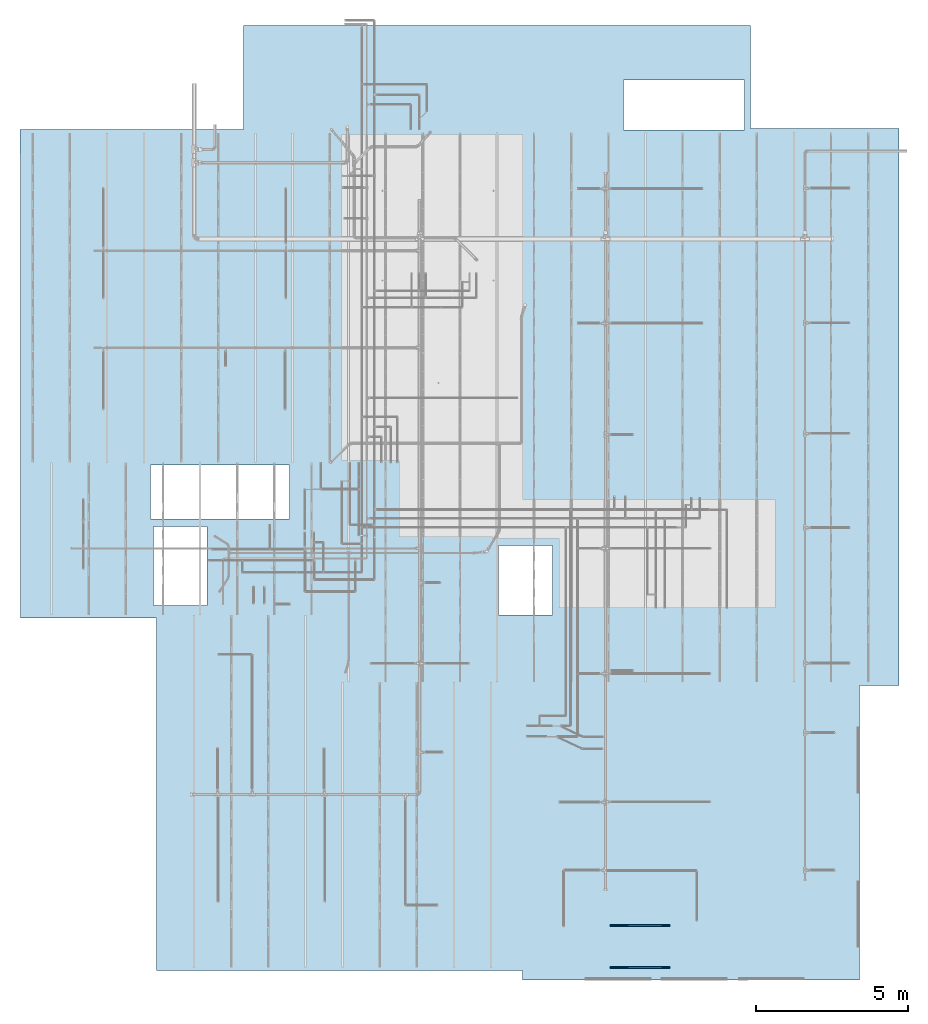
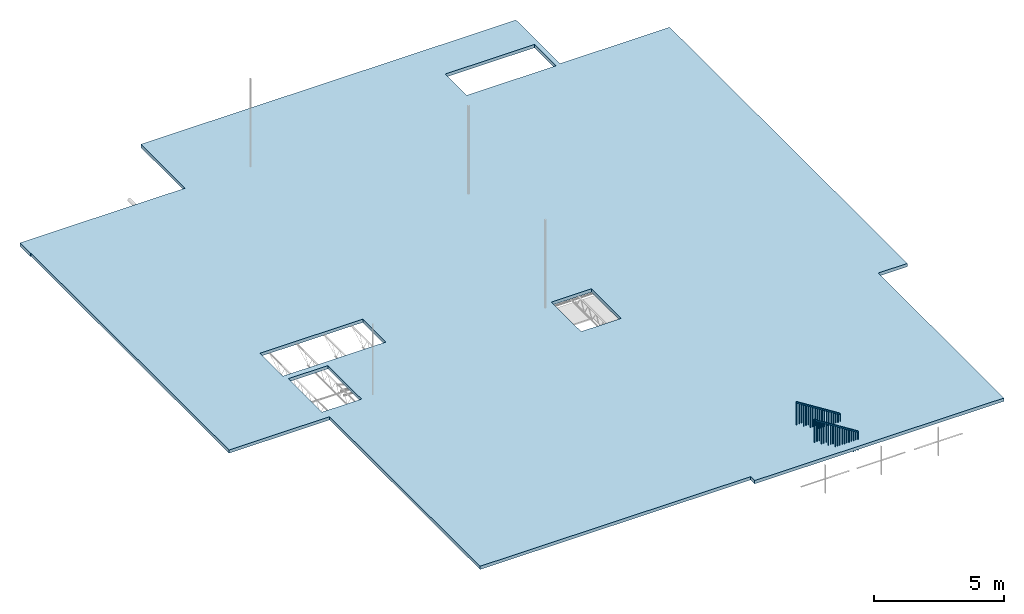
# One storey, part 1 of 173: 2 stairs, 1 slab, 2 elements without a shape of their own.
"""IFC2X3 building model written with IfcOpenShell, lengths in feet."""

from ifc_helpers import new_model, entity, si_unit, converted_unit, derived_unit, direction, frame, origin, place, context, subcontext, project, spatial, polyline, outline, extrude, element, aggregate, save


model = new_model("IFC2X3")

# Units and contexts
model_context = context("Model", 3, precision=0.0001, world=origin(), true_north=direction((6.12303176911189e-17, 1.0)))
body_context = subcontext(model_context, "Body", "Model", "MODEL_VIEW")
ifc_project = project(units=[converted_unit("LENGTHUNIT", "FOOT", entity("IfcRatioMeasure", 0.3048), si_unit("LENGTHUNIT", "METRE"), dimensions=[1, 0, 0, 0, 0, 0, 0]), converted_unit("AREAUNIT", "SQUARE FOOT", entity("IfcRatioMeasure", 0.09290304), si_unit("AREAUNIT", "SQUARE_METRE"), dimensions=[2, 0, 0, 0, 0, 0, 0]), converted_unit("VOLUMEUNIT", "CUBIC FOOT", entity("IfcRatioMeasure", 0.028316846592), si_unit("VOLUMEUNIT", "CUBIC_METRE"), dimensions=[3, 0, 0, 0, 0, 0, 0]), converted_unit("PLANEANGLEUNIT", "DEGREE", entity("IfcRatioMeasure", 0.0174532925199433), si_unit("PLANEANGLEUNIT", "RADIAN"), dimensions=[0, 0, 0, 0, 0, 0, 0]), si_unit("MASSUNIT", "GRAM", prefix="KILO"), derived_unit("MASSDENSITYUNIT", [(si_unit("MASSUNIT", "GRAM", prefix="KILO"), 1), (si_unit("LENGTHUNIT", "METRE"), -3)]), si_unit("TIMEUNIT", "SECOND"), si_unit("FREQUENCYUNIT", "HERTZ"), si_unit("THERMODYNAMICTEMPERATUREUNIT", "DEGREE_CELSIUS"), derived_unit("THERMALTRANSMITTANCEUNIT", [(si_unit("MASSUNIT", "GRAM", prefix="KILO"), 1), (si_unit("THERMODYNAMICTEMPERATUREUNIT", "KELVIN"), -1), (si_unit("TIMEUNIT", "SECOND"), -3)]), derived_unit("VOLUMETRICFLOWRATEUNIT", [(si_unit("LENGTHUNIT", "METRE"), 3), (si_unit("TIMEUNIT", "SECOND"), -1)]), si_unit("ELECTRICCURRENTUNIT", "AMPERE"), si_unit("ELECTRICVOLTAGEUNIT", "VOLT"), si_unit("POWERUNIT", "WATT"), si_unit("FORCEUNIT", "NEWTON"), si_unit("ILLUMINANCEUNIT", "LUX"), si_unit("LUMINOUSFLUXUNIT", "LUMEN"), si_unit("LUMINOUSINTENSITYUNIT", "CANDELA"), derived_unit("USERDEFINED", [(si_unit("MASSUNIT", "GRAM", prefix="KILO"), -1), (si_unit("LENGTHUNIT", "METRE"), -2), (si_unit("TIMEUNIT", "SECOND"), 3), (si_unit("LUMINOUSFLUXUNIT", "LUMEN"), 1)]), derived_unit("LINEARVELOCITYUNIT", [(si_unit("LENGTHUNIT", "METRE"), 1), (si_unit("TIMEUNIT", "SECOND"), -1)]), si_unit("PRESSUREUNIT", "PASCAL"), derived_unit("USERDEFINED", [(si_unit("LENGTHUNIT", "METRE"), -2), (si_unit("MASSUNIT", "GRAM", prefix="KILO"), 1), (si_unit("TIMEUNIT", "SECOND"), -2)])], contexts=[model_context])

# Site, building, storey
site_placement = place(None, origin())
site = spatial("IfcSite", under=ifc_project, at=site_placement, CompositionType="ELEMENT")
building_placement = place(site_placement, origin())
building = spatial("IfcBuilding", under=site, at=building_placement, CompositionType="ELEMENT")
storey_placement = place(building_placement, frame((0.0, 0.0, 8.0)))
storey = spatial("IfcBuildingStorey", under=building, at=storey_placement, Name="REF", CompositionType="ELEMENT", Elevation=8.0)

# Slab
slab_placement = place(storey_placement, origin())
element("IfcSlab", 1, at=slab_placement, inside=storey, PredefinedType="BASESLAB", context=body_context, shape_type="SweptSolid", body=[
    extrude(outline(polyline([(-35.7918682560284, -44.614134098345), (-33.1252015893617, -44.614134098345), (-33.1252015893617, -44.551634098345), (16.8747984106384, -44.551634098345), (16.8747984106384, -29.9093946449186), (54.8747984106383, -29.9093946449186), (54.8747984106383, 9.53169923498843), (55.8747984106383, 9.53169923498843), (55.8747984106383, 45.8650325683218), (24.1247984106383, 45.8650325683218), (24.1247984106383, 50.1150325683217), (-35.8752015893617, 50.1150325683217), (-35.8752015893617, 34.1150325683217), (-46.9569222078015, 34.1150325683217), (-46.9569222078015, -20.551634098345), (-35.7918682560284, -20.551634098345), (-35.7918682560284, -44.614134098345)]), holes=[polyline([(0.385215077304881, -15.5501316478862), (6.20302037068727, -15.5501316478862), (6.20302037068727, -30.5464257650116), (0.385215077304881, -30.5464257650116), (0.385215077304881, -15.5501316478862)]), polyline([(-35.7137432560283, 33.4483659016551), (-35.7137432560283, 20.4240733705836), (-41.1252015893616, 20.4240733705836), (-41.1252015893616, 33.4483659016551), (-35.7137432560283, 33.4483659016551)]), polyline([(7.02757135508617, -24.4667983145529), (15.5275713550862, -24.4667983145529), (15.5275713550862, -30.2167983145529), (7.02757135508617, -30.2167983145529), (7.02757135508617, -24.4667983145529)]), polyline([(9.03257159322918, 12.7852995378091), (16.5325715932292, 12.7852995378091), (16.5325715932292, 6.95196620447572), (9.03257159322918, 6.95196620447572), (9.03257159322918, 12.7852995378091)])]), frame((4.93230003418421, 18.5389050353401, 4.83333333333235), z_axis=(0.0, 0.0, 1.0), x_axis=(0.0, -1.0, 0.0)), (0.0, 0.0, 1.0), 0.5),
])

# Stairs
stair_1_placement = place(storey_placement, origin())
stair_1 = element("IfcStair", 2, at=stair_1_placement, inside=storey, ShapeType="NOTDEFINED")
stair_2_placement = place(stair_1_placement, origin())
stair_2 = element("IfcStair", 3, at=stair_2_placement, ShapeType="NOTDEFINED", context=body_context, shape_type="SweptSolid", body=[
    extrude(outline(polyline([(1.93038615809977, -3.2083333333333), (2.1275848563931, -3.2083333333333), (-1.93038615809977, 3.2083333333333), (-2.1275848563931, 3.20833333333329), (1.93038615809977, -3.2083333333333)])), frame((27.1124658966425, -36.0670854546377, 8.52458905665043), z_axis=(0.0, 1.0, 0.0), x_axis=(0.0, 0.0, 1.0)), (0.0, 0.0, 1.0), 0.166666666666671),
    extrude(outline(polyline([(-1.39151922792843, -0.03125), (1.41128207377824, -0.03125), (1.41128207377824, 0.03125), (-1.43104491962804, 0.03125), (-1.39151922792843, -0.03125)])), frame((30.2895492299758, -36.0150021213044, 5.00548497232896), z_axis=(0.0, 1.0, 0.0), x_axis=(0.0, 0.0, -1.0)), (0.0, 0.0, 1.0), 0.0625),
    extrude(outline(polyline([(-1.6616114545424, -0.03125), (1.6813743003922, -0.03125), (1.6813743003922, 0.03125), (-1.701137146242, 0.03125), (-1.6616114545424, -0.03125)])), frame((23.9353825633091, -36.0150021213043, 8.75383806850814), z_axis=(0.0, 1.0, 0.0), x_axis=(0.0, 0.0, -1.0)), (0.0, 0.0, 1.0), 0.0625),
    extrude(outline(polyline([(-1.48703964953581, -0.03125), (1.50680249538562, -0.03125), (1.50680249538562, 0.03125), (-1.52656534123541, 0.03125), (-1.48703964953581, -0.03125)])), frame((29.9874658966425, -36.0150021213044, 5.10100539393634), z_axis=(0.0, 1.0, 0.0), x_axis=(0.0, 0.0, -1.0)), (0.0, 0.0, 1.0), 0.0625),
    extrude(outline(polyline([(-1.59244149406809, -0.03125), (1.61220433991789, -0.03125), (1.61220433991789, 0.03125), (-1.6319671857677, 0.03125), (-1.59244149406809, -0.03125)])), frame((29.6541325633091, -36.0150021213044, 5.20640723846862), z_axis=(0.0, 1.0, 0.0), x_axis=(0.0, 0.0, -1.0)), (0.0, 0.0, 1.0), 0.0625),
    extrude(outline(polyline([(-1.4079882661366, -0.03125), (1.4277511119864, -0.03125), (1.4277511119864, 0.03125), (-1.44751395783621, 0.03125), (-1.4079882661366, -0.03125)])), frame((29.3207992299758, -36.0150021213044, 5.60166415546466), z_axis=(0.0, 1.0, 0.0), x_axis=(0.0, 0.0, -1.0)), (0.0, 0.0, 1.0), 0.0625),
    extrude(outline(polyline([(-1.51339011066888, -0.03125), (1.53315295651868, -0.03125), (1.53315295651868, 0.03125), (-1.55291580236849, 0.03125), (-1.51339011066888, -0.03125)])), frame((28.9874658966425, -36.0150021213044, 5.70706599999694), z_axis=(0.0, 1.0, 0.0), x_axis=(0.0, 0.0, -1.0)), (0.0, 0.0, 1.0), 0.0625),
    extrude(outline(polyline([(-1.61879195520116, -0.03125), (1.63855480105097, -0.03125), (1.63855480105097, 0.03125), (-1.65831764690077, 0.03125), (-1.61879195520116, -0.03125)])), frame((28.6541325633091, -36.0150021213044, 5.81246784452923), z_axis=(0.0, 1.0, 0.0), x_axis=(0.0, 0.0, -1.0)), (0.0, 0.0, 1.0), 0.0625),
    extrude(outline(polyline([(-1.43433872726967, -0.03125), (1.45410157311947, -0.03125), (1.45410157311947, 0.03125), (-1.47386441896928, 0.03125), (-1.43433872726967, -0.03125)])), frame((28.3207992299758, -36.0150021213044, 6.20772476152527), z_axis=(0.0, 1.0, 0.0), x_axis=(0.0, 0.0, -1.0)), (0.0, 0.0, 1.0), 0.0625),
    extrude(outline(polyline([(-1.53974057180195, -0.0312500000000036), (1.55950341765175, -0.0312500000000036), (1.55950341765175, 0.03125), (-1.57926626350156, 0.03125), (-1.53974057180195, -0.0312500000000036)])), frame((27.9874658966425, -36.0150021213044, 6.31312660605755), z_axis=(0.0, 1.0, 0.0), x_axis=(0.0, 0.0, -1.0)), (0.0, 0.0, 1.0), 0.0625),
    extrude(outline(polyline([(-1.64514241633423, -0.03125), (1.66490526218403, -0.03125), (1.66490526218403, 0.03125), (-1.68466810803383, 0.03125), (-1.64514241633423, -0.03125)])), frame((27.6541325633091, -36.0150021213044, 6.41852845058983), z_axis=(0.0, 1.0, 0.0), x_axis=(0.0, 0.0, -1.0)), (0.0, 0.0, 1.0), 0.0625),
    extrude(outline(polyline([(-1.46068918840274, -0.03125), (1.48045203425254, -0.03125), (1.48045203425254, 0.03125), (-1.50021488010235, 0.03125), (-1.46068918840274, -0.03125)])), frame((27.3207992299758, -36.0150021213044, 6.81378536758587), z_axis=(0.0, 1.0, 0.0), x_axis=(0.0, 0.0, -1.0)), (0.0, 0.0, 1.0), 0.0625),
    extrude(outline(polyline([(-1.56609103293502, -0.03125), (1.58585387878482, -0.03125), (1.58585387878482, 0.03125), (-1.60561672463463, 0.03125), (-1.56609103293502, -0.03125)])), frame((26.9874658966425, -36.0150021213044, 6.91918721211815), z_axis=(0.0, 1.0, 0.0), x_axis=(0.0, 0.0, -1.0)), (0.0, 0.0, 1.0), 0.0625),
    extrude(outline(polyline([(-1.38163780500353, -0.03125), (1.40140065085333, -0.03125), (1.40140065085333, 0.03125), (-1.42116349670314, 0.03125), (-1.38163780500353, -0.03125)])), frame((26.6541325633091, -36.0150021213044, 7.3144441291142), z_axis=(0.0, 1.0, 0.0), x_axis=(0.0, 0.0, -1.0)), (0.0, 0.0, 1.0), 0.0625),
    extrude(outline(polyline([(-1.48703964953581, -0.03125), (1.50680249538561, -0.03125), (1.50680249538561, 0.03125), (-1.52656534123541, 0.03125), (-1.48703964953581, -0.03125)])), frame((26.3207992299758, -36.0150021213044, 7.41984597364648), z_axis=(0.0, 1.0, 0.0), x_axis=(0.0, 0.0, -1.0)), (0.0, 0.0, 1.0), 0.0625),
    extrude(outline(polyline([(-1.59244149406809, -0.03125), (1.61220433991789, -0.03125), (1.61220433991789, 0.03125), (-1.6319671857677, 0.03125), (-1.59244149406809, -0.03125)])), frame((25.9874658966425, -36.0150021213044, 7.52524781817876), z_axis=(0.0, 1.0, 0.0), x_axis=(0.0, 0.0, -1.0)), (0.0, 0.0, 1.0), 0.0625),
    extrude(outline(polyline([(-1.4079882661366, -0.03125), (1.4277511119864, -0.03125), (1.4277511119864, 0.03125), (-1.44751395783621, 0.03125), (-1.4079882661366, -0.03125)])), frame((25.6541325633091, -36.0150021213044, 7.92050473517481), z_axis=(0.0, 1.0, 0.0), x_axis=(0.0, 0.0, -1.0)), (0.0, 0.0, 1.0), 0.0625),
    extrude(outline(polyline([(-1.51339011066888, -0.03125), (1.53315295651868, -0.03125), (1.53315295651868, 0.03125), (-1.55291580236849, 0.03125), (-1.51339011066888, -0.03125)])), frame((25.3207992299758, -36.0150021213043, 8.02590657970709), z_axis=(0.0, 1.0, 0.0), x_axis=(0.0, 0.0, -1.0)), (0.0, 0.0, 1.0), 0.0625),
    extrude(outline(polyline([(-1.61879195520116, -0.03125), (1.63855480105096, -0.03125), (1.63855480105096, 0.03125), (-1.65831764690077, 0.03125), (-1.61879195520116, -0.03125)])), frame((24.9874658966425, -36.0150021213043, 8.13130842423936), z_axis=(0.0, 1.0, 0.0), x_axis=(0.0, 0.0, -1.0)), (0.0, 0.0, 1.0), 0.0625),
    extrude(outline(polyline([(-1.43433872726967, -0.03125), (1.45410157311948, -0.03125), (1.45410157311948, 0.03125), (-1.47386441896927, 0.03125), (-1.43433872726967, -0.03125)])), frame((24.6541325633091, -36.0150021213043, 8.52656534123542), z_axis=(0.0, 1.0, 0.0), x_axis=(0.0, 0.0, -1.0)), (0.0, 0.0, 1.0), 0.0625),
    extrude(outline(polyline([(-1.53974057180195, -0.03125), (1.55950341765175, -0.03125), (1.55950341765175, 0.0312500000000036), (-1.57926626350156, 0.0312500000000036), (-1.53974057180195, -0.03125)])), frame((24.3207992299758, -36.0150021213043, 8.63196718576769), z_axis=(0.0, 1.0, 0.0), x_axis=(0.0, 0.0, -1.0)), (0.0, 0.0, 1.0), 0.0625),
    extrude(outline(polyline([(-1.64514241633423, -0.03125), (1.66490526218403, -0.03125), (1.66490526218403, 0.03125), (-1.68466810803383, 0.03125), (-1.64514241633423, -0.03125)])), frame((23.9874658966425, -36.0150021213043, 8.73736903029998), z_axis=(0.0, 1.0, 0.0), x_axis=(0.0, 0.0, -1.0)), (0.0, 0.0, 1.0), 0.0625),
])
aggregate(stair_1, [stair_2])

stair_3_placement = place(storey_placement, origin())
stair_3 = element("IfcStair", 4, at=stair_3_placement, inside=storey, ShapeType="NOTDEFINED")
stair_4_placement = place(stair_3_placement, origin())
stair_4 = element("IfcStair", 5, at=stair_4_placement, ShapeType="NOTDEFINED", context=body_context, shape_type="SweptSolid", body=[
    extrude(outline(polyline([(1.93038615809971, -3.20833333333334), (2.12758485639304, -3.20833333333334), (-1.93038615809971, 3.20833333333334), (-2.12758485639304, 3.20833333333334), (1.93038615809971, -3.20833333333334)])), frame((27.1124658966425, -31.5692880800518, 8.52458905665043), z_axis=(0.0, 1.0, 0.0), x_axis=(0.0, 0.0, 1.0)), (0.0, 0.0, 1.0), 0.166666666666664),
    extrude(outline(polyline([(-0.03125, -1.41128207377824), (0.03125, -1.41128207377824), (0.03125, 1.43104491962804), (-0.03125, 1.39151922792843), (-0.03125, -1.41128207377824)])), frame((30.2895492299758, -31.5172047467184, 5.00548497232896), z_axis=(0.0, 1.0, 0.0), x_axis=(-1.0, 0.0, 0.0)), (0.0, 0.0, 1.0), 0.0625),
    extrude(outline(polyline([(-0.03125, -1.6813743003922), (0.03125, -1.6813743003922), (0.03125, 1.701137146242), (-0.03125, 1.6616114545424), (-0.03125, -1.6813743003922)])), frame((23.9353825633091, -31.5172047467184, 8.75383806850814), z_axis=(0.0, 1.0, 0.0), x_axis=(-1.0, 0.0, 0.0)), (0.0, 0.0, 1.0), 0.0625),
    extrude(outline(polyline([(-0.03125, -1.50680249538561), (0.03125, -1.50680249538561), (0.03125, 1.52656534123542), (-0.03125, 1.48703964953581), (-0.03125, -1.50680249538561)])), frame((29.9874658966425, -31.5172047467184, 5.10100539393634), z_axis=(0.0, 1.0, 0.0), x_axis=(-1.0, 0.0, 0.0)), (0.0, 0.0, 1.0), 0.0625),
    extrude(outline(polyline([(-0.03125, -1.61220433991789), (0.03125, -1.61220433991789), (0.03125, 1.6319671857677), (-0.03125, 1.59244149406809), (-0.03125, -1.61220433991789)])), frame((29.6541325633091, -31.5172047467184, 5.20640723846862), z_axis=(0.0, 1.0, 0.0), x_axis=(-1.0, 0.0, 0.0)), (0.0, 0.0, 1.0), 0.0625),
    extrude(outline(polyline([(-0.03125, -1.4277511119864), (0.03125, -1.4277511119864), (0.03125, 1.44751395783621), (-0.03125, 1.4079882661366), (-0.03125, -1.4277511119864)])), frame((29.3207992299758, -31.5172047467184, 5.60166415546467), z_axis=(0.0, 1.0, 0.0), x_axis=(-1.0, 0.0, 0.0)), (0.0, 0.0, 1.0), 0.0625),
    extrude(outline(polyline([(-0.03125, -1.53315295651868), (0.03125, -1.53315295651868), (0.03125, 1.55291580236849), (-0.03125, 1.51339011066888), (-0.03125, -1.53315295651868)])), frame((28.9874658966425, -31.5172047467184, 5.70706599999694), z_axis=(0.0, 1.0, 0.0), x_axis=(-1.0, 0.0, 0.0)), (0.0, 0.0, 1.0), 0.0625),
    extrude(outline(polyline([(-0.03125, -1.63855480105096), (0.03125, -1.63855480105096), (0.03125, 1.65831764690077), (-0.03125, 1.61879195520116), (-0.03125, -1.63855480105096)])), frame((28.6541325633091, -31.5172047467184, 5.81246784452922), z_axis=(0.0, 1.0, 0.0), x_axis=(-1.0, 0.0, 0.0)), (0.0, 0.0, 1.0), 0.0625),
    extrude(outline(polyline([(-0.03125, -1.45410157311948), (0.03125, -1.45410157311948), (0.03125, 1.47386441896927), (-0.03125, 1.43433872726967), (-0.03125, -1.45410157311948)])), frame((28.3207992299758, -31.5172047467184, 6.20772476152527), z_axis=(0.0, 1.0, 0.0), x_axis=(-1.0, 0.0, 0.0)), (0.0, 0.0, 1.0), 0.0625),
    extrude(outline(polyline([(-0.03125, -1.55950341765175), (0.03125, -1.55950341765175), (0.03125, 1.57926626350156), (-0.03125, 1.53974057180195), (-0.03125, -1.55950341765175)])), frame((27.9874658966425, -31.5172047467184, 6.31312660605755), z_axis=(0.0, 1.0, 0.0), x_axis=(-1.0, 0.0, 0.0)), (0.0, 0.0, 1.0), 0.0625),
    extrude(outline(polyline([(-0.03125, -1.66490526218403), (0.03125, -1.66490526218403), (0.03125, 1.68466810803383), (-0.03125, 1.64514241633423), (-0.03125, -1.66490526218403)])), frame((27.6541325633091, -31.5172047467184, 6.41852845058983), z_axis=(0.0, 1.0, 0.0), x_axis=(-1.0, 0.0, 0.0)), (0.0, 0.0, 1.0), 0.0625),
    extrude(outline(polyline([(-0.03125, -1.48045203425254), (0.03125, -1.48045203425254), (0.03125, 1.50021488010234), (-0.03125, 1.46068918840274), (-0.03125, -1.48045203425254)])), frame((27.3207992299758, -31.5172047467184, 6.81378536758588), z_axis=(0.0, 1.0, 0.0), x_axis=(-1.0, 0.0, 0.0)), (0.0, 0.0, 1.0), 0.0625),
    extrude(outline(polyline([(-0.03125, -1.58585387878482), (0.03125, -1.58585387878482), (0.03125, 1.60561672463462), (-0.03125, 1.56609103293502), (-0.03125, -1.58585387878482)])), frame((26.9874658966425, -31.5172047467184, 6.91918721211816), z_axis=(0.0, 1.0, 0.0), x_axis=(-1.0, 0.0, 0.0)), (0.0, 0.0, 1.0), 0.0625),
    extrude(outline(polyline([(-0.03125, -1.40140065085333), (0.03125, -1.40140065085333), (0.03125, 1.42116349670314), (-0.03125, 1.38163780500353), (-0.03125, -1.40140065085333)])), frame((26.6541325633091, -31.5172047467184, 7.3144441291142), z_axis=(0.0, 1.0, 0.0), x_axis=(-1.0, 0.0, 0.0)), (0.0, 0.0, 1.0), 0.0625),
    extrude(outline(polyline([(-0.03125, -1.50680249538561), (0.03125, -1.50680249538561), (0.03125, 1.52656534123541), (-0.03125, 1.48703964953581), (-0.03125, -1.50680249538561)])), frame((26.3207992299758, -31.5172047467184, 7.41984597364648), z_axis=(0.0, 1.0, 0.0), x_axis=(-1.0, 0.0, 0.0)), (0.0, 0.0, 1.0), 0.0625),
    extrude(outline(polyline([(-0.03125, -1.61220433991789), (0.03125, -1.61220433991789), (0.03125, 1.6319671857677), (-0.03125, 1.59244149406809), (-0.03125, -1.61220433991789)])), frame((25.9874658966425, -31.5172047467184, 7.52524781817876), z_axis=(0.0, 1.0, 0.0), x_axis=(-1.0, 0.0, 0.0)), (0.0, 0.0, 1.0), 0.0625),
    extrude(outline(polyline([(-0.03125, -1.4277511119864), (0.03125, -1.4277511119864), (0.03125, 1.44751395783621), (-0.03125, 1.4079882661366), (-0.03125, -1.4277511119864)])), frame((25.6541325633091, -31.5172047467184, 7.92050473517481), z_axis=(0.0, 1.0, 0.0), x_axis=(-1.0, 0.0, 0.0)), (0.0, 0.0, 1.0), 0.0625),
    extrude(outline(polyline([(-0.03125, -1.53315295651868), (0.03125, -1.53315295651868), (0.03125, 1.55291580236849), (-0.03125, 1.51339011066888), (-0.03125, -1.53315295651868)])), frame((25.3207992299758, -31.5172047467184, 8.02590657970709), z_axis=(0.0, 1.0, 0.0), x_axis=(-1.0, 0.0, 0.0)), (0.0, 0.0, 1.0), 0.0625),
    extrude(outline(polyline([(-0.03125, -1.63855480105096), (0.03125, -1.63855480105096), (0.03125, 1.65831764690077), (-0.03125, 1.61879195520116), (-0.03125, -1.63855480105096)])), frame((24.9874658966425, -31.5172047467184, 8.13130842423936), z_axis=(0.0, 1.0, 0.0), x_axis=(-1.0, 0.0, 0.0)), (0.0, 0.0, 1.0), 0.0625),
    extrude(outline(polyline([(-0.03125, -1.45410157311948), (0.03125, -1.45410157311948), (0.03125, 1.47386441896927), (-0.03125, 1.43433872726967), (-0.03125, -1.45410157311948)])), frame((24.6541325633091, -31.5172047467184, 8.52656534123542), z_axis=(0.0, 1.0, 0.0), x_axis=(-1.0, 0.0, 0.0)), (0.0, 0.0, 1.0), 0.0625),
    extrude(outline(polyline([(-0.03125, -1.55950341765175), (0.03125, -1.55950341765175), (0.03125, 1.57926626350156), (-0.03125, 1.53974057180195), (-0.03125, -1.55950341765175)])), frame((24.3207992299758, -31.5172047467184, 8.63196718576769), z_axis=(0.0, 1.0, 0.0), x_axis=(-1.0, 0.0, 0.0)), (0.0, 0.0, 1.0), 0.0625),
    extrude(outline(polyline([(-0.03125, -1.66490526218403), (0.03125, -1.66490526218403), (0.03125, 1.68466810803383), (-0.03125, 1.64514241633423), (-0.03125, -1.66490526218403)])), frame((23.9874658966425, -31.5172047467184, 8.73736903029998), z_axis=(0.0, 1.0, 0.0), x_axis=(-1.0, 0.0, 0.0)), (0.0, 0.0, 1.0), 0.0625),
])
aggregate(stair_3, [stair_4])

save(model, "model.ifc")
